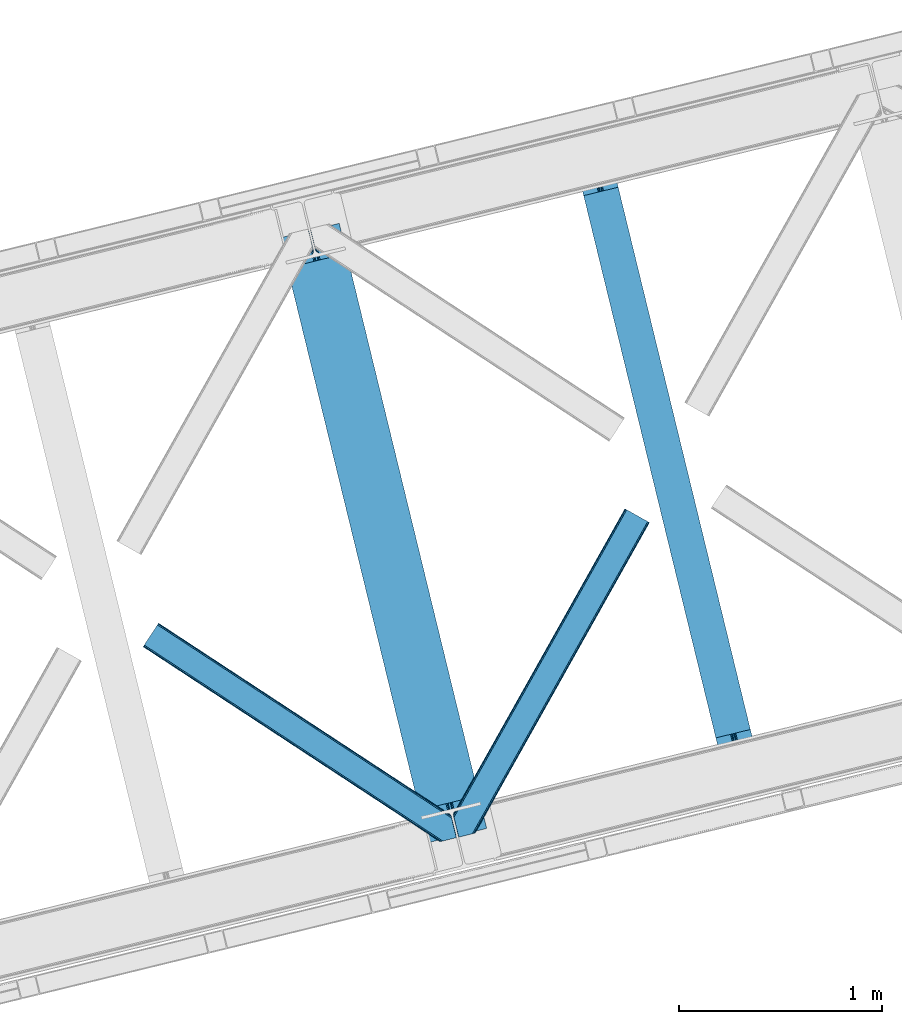
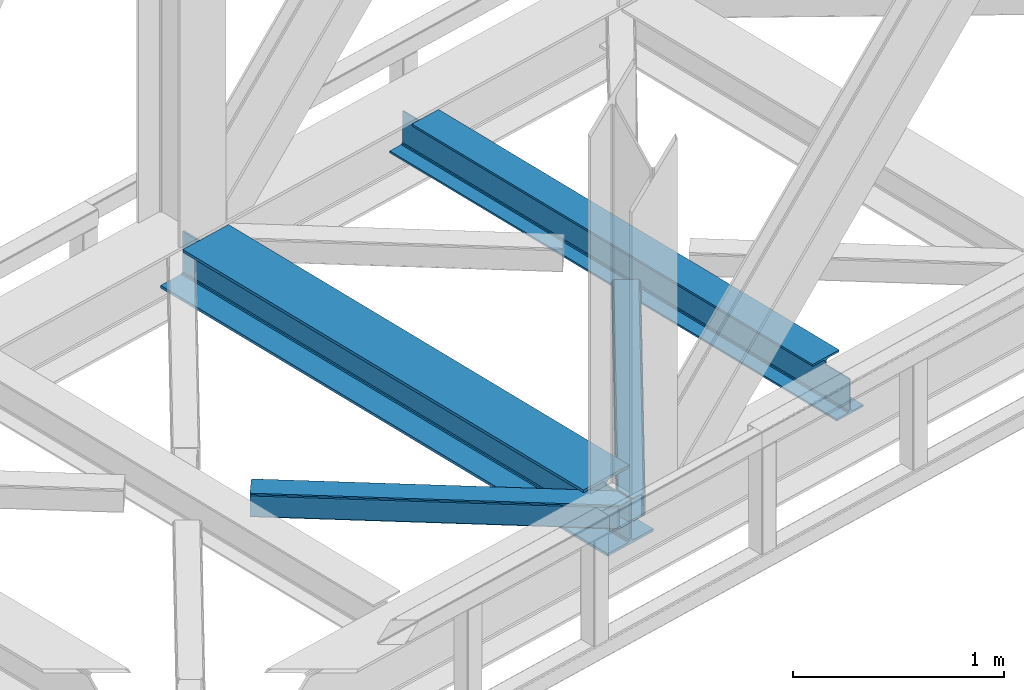
# One storey, part 78 of 93: 2 beams, 2 members.
"""IFC4 building model written with IfcOpenShell, lengths in millimetres."""

from ifc_helpers import new_model, entity, si_unit, converted_unit, derived_unit, direction, frame, origin, place, context, subcontext, project, spatial, triangles, polygons, material, type_object, element, save


model = new_model("IFC4")

# Units and contexts
model_context = context("Model", 3, precision=0.01, world=origin(), true_north=direction((6.12303176911189e-17, 1.0)))
plan_context = context("Plan", 3, precision=0.01, world=origin(), true_north=direction((6.12303176911189e-17, 1.0)))
body_context = subcontext(model_context, "Body", "Model", "MODEL_VIEW")
ifc_project = project(units=[si_unit("LENGTHUNIT", "METRE", prefix="MILLI"), si_unit("AREAUNIT", "SQUARE_METRE"), si_unit("VOLUMEUNIT", "CUBIC_METRE"), converted_unit("PLANEANGLEUNIT", "DEGREE", entity("IfcRatioMeasure", 0.0174532925199433), si_unit("PLANEANGLEUNIT", "RADIAN"), dimensions=[0, 0, 0, 0, 0, 0, 0]), si_unit("MASSUNIT", "GRAM", prefix="KILO"), derived_unit("MASSDENSITYUNIT", [(si_unit("MASSUNIT", "GRAM", prefix="KILO"), 1), (si_unit("LENGTHUNIT", "METRE"), -3)]), derived_unit("MOMENTOFINERTIAUNIT", [(si_unit("LENGTHUNIT", "METRE"), 4)]), si_unit("TIMEUNIT", "SECOND"), si_unit("FREQUENCYUNIT", "HERTZ"), si_unit("THERMODYNAMICTEMPERATUREUNIT", "DEGREE_CELSIUS"), derived_unit("THERMALTRANSMITTANCEUNIT", [(si_unit("MASSUNIT", "GRAM", prefix="KILO"), 1), (si_unit("THERMODYNAMICTEMPERATUREUNIT", "KELVIN"), -1), (si_unit("TIMEUNIT", "SECOND"), -3)]), derived_unit("VOLUMETRICFLOWRATEUNIT", [(si_unit("LENGTHUNIT", "METRE"), 3), (si_unit("TIMEUNIT", "SECOND"), -1)]), derived_unit("MASSFLOWRATEUNIT", [(si_unit("MASSUNIT", "GRAM", prefix="KILO"), 1), (si_unit("TIMEUNIT", "SECOND"), -1)]), derived_unit("ROTATIONALFREQUENCYUNIT", [(si_unit("TIMEUNIT", "SECOND"), -1)]), si_unit("ELECTRICCURRENTUNIT", "AMPERE"), si_unit("ELECTRICVOLTAGEUNIT", "VOLT"), si_unit("POWERUNIT", "WATT"), si_unit("FORCEUNIT", "NEWTON", prefix="KILO"), si_unit("ILLUMINANCEUNIT", "LUX"), si_unit("LUMINOUSFLUXUNIT", "LUMEN"), si_unit("LUMINOUSINTENSITYUNIT", "CANDELA"), derived_unit("USERDEFINED", [(si_unit("MASSUNIT", "GRAM", prefix="KILO"), -1), (si_unit("LENGTHUNIT", "METRE"), -2), (si_unit("TIMEUNIT", "SECOND"), 3), (si_unit("LUMINOUSFLUXUNIT", "LUMEN"), 1)]), derived_unit("LINEARVELOCITYUNIT", [(si_unit("LENGTHUNIT", "METRE"), 1), (si_unit("TIMEUNIT", "SECOND"), -1)]), si_unit("PRESSUREUNIT", "PASCAL"), derived_unit("USERDEFINED", [(si_unit("LENGTHUNIT", "METRE"), -2), (si_unit("MASSUNIT", "GRAM", prefix="KILO"), 1), (si_unit("TIMEUNIT", "SECOND"), -2)]), derived_unit("LINEARFORCEUNIT", [(si_unit("MASSUNIT", "GRAM", prefix="KILO"), 1), (si_unit("LENGTHUNIT", "METRE"), 1), (si_unit("TIMEUNIT", "SECOND"), -2), (si_unit("LENGTHUNIT", "METRE"), -1)]), derived_unit("PLANARFORCEUNIT", [(si_unit("MASSUNIT", "GRAM", prefix="KILO"), 1), (si_unit("LENGTHUNIT", "METRE"), 1), (si_unit("TIMEUNIT", "SECOND"), -2), (si_unit("LENGTHUNIT", "METRE"), -2)])], contexts=[model_context, plan_context])

# Site, building, storey
site_placement = place(None, origin())
site = spatial("IfcSite", under=ifc_project, at=site_placement, CompositionType="ELEMENT")
building_placement = place(site_placement, origin())
building = spatial("IfcBuilding", under=site, at=building_placement, CompositionType="ELEMENT")
storey_placement = place(building_placement, frame((0.0, 0.0, 15900.0)))
storey = spatial("IfcBuildingStorey", under=building, at=storey_placement, CompositionType="ELEMENT", Elevation=15900.0)

# Beams
ifc_material = material(Name="Metal painted (White)")
beam_type = type_object("IfcBeamType", PredefinedType="BEAM")
beam_1_placement = place(storey_placement, frame((-9086.33270000327, 15580.0394855194, 3385.0)))
element("IfcBeam", 1, at=beam_1_placement, inside=storey, type_object=beam_type, material=ifc_material, ObjectType="Steel Beam", PredefinedType="BEAM", context=body_context, shape_type="Tessellation", body=[
    polygons([(1018.1664837833, 71.0478278971021, 15.4999999999986), (1018.1664837833, 71.0478278971021, 0.0), (291.465617442452, 3052.25531830421, 0.0), (291.465617442452, 3052.25531830421, 15.4999999999986), (894.779372399334, 40.9709140873313, 15.4999999999986), (168.078506058486, 3022.17840449444, 15.4999999999986), (888.08702862538, 39.3395844888265, 16.8701684147963), (161.386162284532, 3020.54707489594, 16.8701684147963), (882.413533524765, 37.956610033654, 20.7720779386456), (155.712667183913, 3019.16410044077, 20.7720779386456), (878.622625296187, 37.0325360459184, 26.6116982174294), (151.921758955338, 3018.24002645303, 26.6116982174294), (877.291435352789, 36.7080444135029, 33.500000000001), (150.590569011938, 3017.91553482062, 33.500000000001), (140.875048430526, 3015.54727389071, 33.500000000001), (140.875048430525, 3015.54727389071, 259.000000000002), (150.590569011936, 3017.91553482062, 259.000000000002), (0.0, 2981.20749040711, 0.0), (3.24860138789518e-12, 2981.20749040711, 15.4999999999986), (123.387111383965, 3011.28440421689, 15.4999999999986), (130.079455157938, 3012.91573381539, 16.8701684147963), (135.752950258552, 3014.29870827056, 20.7720779386369), (139.543858487129, 3015.2227822583, 26.6116982174294), (877.291435352786, 36.7080444135029, 259.000000000002), (867.575914771374, 34.3397834836014, 259.000000000002), (867.575914771377, 34.3397834836014, 33.500000000001), (866.24472482798, 34.0152918511859, 26.6116982174294), (862.453816599403, 33.0912178634502, 20.7720779386369), (856.780321498787, 31.70824340828, 16.8701684147963), (850.087977724816, 30.0769138097708, 15.4999999999986), (726.700866340855, 0.0, 15.4999999999986), (726.700866340851, 0.0, 0.0), (838.124523615913, 197.385937999181, 259.069791973884), (186.469722099971, 2870.72539801219, 259.000000000002), (186.693115201823, 2869.80895360721, 259.61730333112), (186.70550404545, 2869.75812937344, 266.500003008253), (837.979344808147, 197.981416001704, 266.500002998871), (837.979694928899, 197.979979696973, 260.000004007589), (828.499586345882, 194.645865944434, 259.006343171919), (828.27621632612, 195.562317481914, 259.61730333112), (828.263827482491, 195.613141715687, 266.500003008253), (176.989986719794, 2867.38985508742, 266.500002998871), (176.989636599042, 2867.39129139215, 260.000004007589), (176.844830940702, 2867.98534020594, 259.07612046749), (176.75420151856, 2868.35713708228, 259.000000000002), (839.310832678078, 198.30468544639, 273.388305639783), (843.101109266769, 199.231350618303, 279.227924098777), (848.774180214308, 200.616065081981, 283.129832400619), (855.466371895439, 202.248018612794, 284.500000377228), (978.853400583268, 232.325271667905, 284.500000138971), (978.851730776625, 232.332121736637, 299.999995328161), (687.386308679347, 161.283492472596, 299.999995890962), (687.387978486002, 161.276642403863, 284.500000701776), (810.775007173842, 191.353895458974, 284.500000463519), (817.467494070002, 192.984637925557, 283.129832461069), (823.141405718754, 194.365903570079, 279.227924137322), (826.93294050575, 195.287407219375, 273.388305663684), (175.658498849867, 2867.06658564273, 273.388305639783), (171.868222261169, 2866.13992047082, 279.227924098781), (166.195151313643, 2864.75520600715, 283.129832400619), (159.502959632494, 2863.12325247633, 284.500000377228), (36.1159309446587, 2833.04599942122, 284.500000138971), (36.117600751305, 2833.03914935249, 299.999995328161), (327.583022848581, 2904.08777861653, 299.999995890962), (327.581353041927, 2904.09462868526, 284.500000701776), (204.194324354092, 2874.01737563015, 284.500000463519), (197.50183745795, 2872.38663316357, 283.129832461069), (191.827925809185, 2871.00536751905, 279.227924137318), (188.036391022194, 2870.08386386975, 273.388305663684)], [[[1, 2, 3, 4]], [[5, 1, 4, 6]], [[7, 5, 6, 8]], [[9, 7, 8, 10]], [[11, 9, 10, 12]], [[13, 11, 12, 14]], [[15, 16, 17, 14, 12, 10, 8, 6, 4, 3, 18, 19, 20, 21, 22, 23]], [[13, 24, 25, 26, 27, 28, 29, 30, 31, 32, 2, 1, 5, 7, 9, 11]], [[2, 32, 18, 3]], [[32, 31, 19, 18]], [[31, 30, 20, 19]], [[27, 26, 15, 23]], [[28, 27, 23, 22]], [[29, 28, 22, 21]], [[30, 29, 21, 20]], [[33, 24, 13, 14, 17, 34, 35, 36, 37, 38]], [[25, 39, 40, 41, 42, 43, 44, 16, 15, 26]], [[39, 25, 24, 33]], [[45, 34, 17, 16]], [[41, 40, 38, 37, 46, 47, 48, 49, 50, 51, 52, 53, 54, 55, 56, 57]], [[42, 58, 59, 60, 61, 62, 63, 64, 65, 66, 67, 68, 69, 36, 35, 43]], [[46, 37, 36, 69]], [[47, 46, 69, 68]], [[48, 47, 68, 67]], [[49, 48, 67, 66]], [[50, 49, 66, 65]], [[51, 50, 65, 64]], [[52, 51, 64, 63]], [[53, 52, 63, 62]], [[54, 53, 62, 61]], [[55, 54, 61, 60]], [[56, 55, 60, 59]], [[57, 56, 59, 58]], [[41, 57, 58, 42]]], closed=False),
])
beam_2_placement = place(storey_placement, frame((-7626.57573264569, 15935.8706902374, 3441.0)))
element("IfcBeam", 2, at=beam_2_placement, inside=storey, type_object=beam_type, material=ifc_material, ObjectType="Steel Beam", PredefinedType="BEAM", context=body_context, shape_type="Tessellation", body=[
    polygons([(896.722476515611, 41.4445662733103, 11.000000000004), (896.722476515614, 41.4445662733103, 2.16573425859679e-12), (170.021610174762, 3022.65205668042, 2.16573425859679e-12), (170.02161017476, 3022.65205668042, 11.000000000004), (830.656936561979, 25.3403919499634, 11.000000000004), (103.956070221129, 3006.54788235708, 11.000000000004), (824.708186540692, 23.8903211957374, 12.2179274798217), (98.0073201998416, 3005.09781160285, 12.2179274798217), (819.665079784588, 22.6610105689172, 15.686291501017), (92.9642134437373, 3003.86850097603, 15.686291501017), (816.295383581406, 21.8396114687097, 20.8770650821657), (89.594517240556, 3003.04710187582, 20.8770650821657), (815.112103631725, 21.5511744621184, 27.0000000000047), (88.4112372908755, 3002.75866486923, 27.0000000000047), (81.6103728838779, 3001.1008822183, 27.0000000000047), (81.6103728838768, 3001.1008822183, 203.000000000006), (88.411237290882, 3002.75866486923, 203.000000000006), (3.24860138789518e-12, 2981.20749040711, 2.16573425859679e-12), (3.24860138789518e-12, 2981.20749040711, 10.9999999999997), (66.0655399536161, 2997.31166473045, 11.000000000004), (72.0142899749205, 2998.76173548468, 12.2179274798217), (77.0573967310281, 2999.9910461115, 15.6862915010192), (80.427092934204, 3000.81244521171, 20.8770650821657), (815.112103631733, 21.5511744621227, 203.000000000006), (808.311239224728, 19.8933918111854, 203.000000000006), (808.311239224728, 19.8933918111854, 27.0000000000047), (807.127959275053, 19.6049548045984, 20.8770650821657), (803.758263071879, 18.7835557043887, 15.6862915010192), (798.715156315771, 17.5542450775707, 12.2179274798217), (792.766406294467, 16.1041743233403, 11.000000000004), (726.700866340853, 2.16573425859679e-12, 10.9999999999997), (726.700866340856, 2.16573425859679e-12, 2.16573425859679e-12), (775.945201911976, 182.229070489532, 203.069792164282), (124.290390378929, 2855.5685280608, 203.000000000006), (124.513271168076, 2854.65418562638, 203.617301946336), (124.526185412596, 2854.60120565348, 217.000003693143), (775.799998669246, 182.824605273256, 217.000003676718), (775.800869277144, 182.821033832377, 204.00000679514), (769.2349007589, 180.199471824625, 203.006342981088), (769.012053092174, 181.113823838952, 203.617301946336), (768.999138847647, 181.166803811845, 217.000003693143), (117.725325590999, 2852.94340419207, 217.000003676718), (117.724454983107, 2852.94697563295, 204.00000679514), (117.580155394048, 2853.53894853353, 203.076120467494), (117.489525971923, 2853.91074540987, 203.000000000006), (776.983483393265, 183.112202246694, 223.122939328039), (780.352479801945, 183.936472070573, 228.313710402595), (785.395115205969, 185.167716295879, 231.782072735464), (791.343694076666, 186.618489150559, 232.999999602236), (857.4091449422, 202.723028934495, 232.999999283132), (857.407671605763, 202.729072911368, 243.999994005812), (687.386290701845, 161.28356611448, 243.999994827032), (687.387764038282, 161.277522137607, 233.000000104353), (753.453214903794, 177.382061921539, 232.999999785253), (759.402120032139, 178.831496389766, 231.782072861012), (764.445684539266, 180.058929212901, 228.313710479427), (767.816071449004, 180.87749487033, 223.12293937232), (116.541840866978, 2852.65580721863, 223.122939328039), (113.172844458302, 2851.83153739476, 228.313710402595), (108.130209054283, 2850.60029316945, 231.782072735464), (102.181630183566, 2849.14952031477, 232.999999602236), (36.1161793180469, 2833.04498053083, 232.999999283128), (36.1176526544877, 2833.03893655396, 243.999994005812), (206.139033558404, 2874.48444335085, 243.999994827032), (206.137560221967, 2874.49048732772, 233.000000104357), (140.072109356437, 2858.38594754379, 232.999999785253), (134.123204228111, 2856.93651307557, 231.782072861012), (129.079639720983, 2855.70908025243, 228.313710479427), (125.709252811239, 2854.890514595, 223.12293937232)], [[[1, 2, 3, 4]], [[5, 1, 4, 6]], [[7, 5, 6, 8]], [[9, 7, 8, 10]], [[11, 9, 10, 12]], [[13, 11, 12, 14]], [[15, 16, 17, 14, 12, 10, 8, 6, 4, 3, 18, 19, 20, 21, 22, 23]], [[13, 24, 25, 26, 27, 28, 29, 30, 31, 32, 2, 1, 5, 7, 9, 11]], [[2, 32, 18, 3]], [[32, 31, 19, 18]], [[31, 30, 20, 19]], [[27, 26, 15, 23]], [[28, 27, 23, 22]], [[29, 28, 22, 21]], [[30, 29, 21, 20]], [[33, 24, 13, 14, 17, 34, 35, 36, 37, 38]], [[25, 39, 40, 41, 42, 43, 44, 16, 15, 26]], [[39, 25, 24, 33]], [[45, 34, 17, 16]], [[41, 40, 38, 37, 46, 47, 48, 49, 50, 51, 52, 53, 54, 55, 56, 57]], [[42, 58, 59, 60, 61, 62, 63, 64, 65, 66, 67, 68, 69, 36, 35, 43]], [[46, 37, 36, 69]], [[47, 46, 69, 68]], [[48, 47, 68, 67]], [[49, 48, 67, 66]], [[50, 49, 66, 65]], [[51, 50, 65, 64]], [[52, 51, 64, 63]], [[53, 52, 63, 62]], [[54, 53, 62, 61]], [[55, 54, 61, 60]], [[56, 55, 60, 59]], [[57, 56, 59, 58]], [[41, 57, 58, 42]]], closed=False),
])

# Members
member_type_1 = type_object("IfcMemberType", PredefinedType="BRACE")
member_1_placement = place(storey_placement, frame((-8233.36081695557, 15608.2403137207, 3510.00011901855)))
element("IfcMember", 3, at=member_1_placement, inside=storey, type_object=member_type_1, ObjectType="Steel Horizontal Brace", PredefinedType="BRACE", context=body_context, shape_type="Tessellation", body=[
    triangles([(967.681050109863, 1549.66471252441, 122.500662231447), (966.521237182617, 1550.31699829101, 129.197927856447), (108.493377685547, 19.761584472657, 122.500662231447), (106.721974182128, 19.3302154541016, 129.197927856447), (963.215043640136, 1552.17502441406, 134.874325561526), (101.679258728027, 18.1012207031254, 134.874325561526), (958.263020324707, 1554.95392456055, 138.667117309571), (94.1378585815428, 16.2629608154293, 138.667117309571), (952.422679138183, 1558.23395690918, 139.999594116212), (85.2360763549805, 14.0921630859375, 139.999594116212), (967.681050109863, 1549.66471252441, 17.5000946044929), (108.493377685547, 19.761584472657, 17.5000946044929), (6.07462921142542, 87.5702362060547, 139.999594116212), (27.4210006713856, 0.0, 139.999594116212), (860.874778747559, 1609.64826049805, 139.999594116212), (855.034437561035, 1612.92829284668, 138.667117309571), (3.74977111816406, 97.1068634033199, 138.667117309571), (850.082414245605, 1615.70719299316, 134.874325561526), (1.77896118164063, 105.192416381837, 134.874325561526), (846.776220703125, 1617.56521911621, 129.197927856447), (0.462181091308594, 110.594412231445, 129.197927856447), (845.616407775879, 1618.21750488281, 122.500662231447), (0.0, 112.491970825195, 122.500662231447), (845.616407775879, 1618.21750488281, 17.5000946044929), (0.0, 112.491970825195, 17.5000946044929), (966.521237182617, 1550.31699829101, 10.8028289794929), (106.721974182128, 19.3302154541016, 10.8028289794929), (156.767756652832, 115.413885498047, 5.52059326172093), (963.215043640136, 1552.17502441406, 5.12526855468968), (156.952047729492, 116.778918457032, 5.02062377929906), (102.189692687988, 18.2256317138672, 5.52059326172093), (958.263020324707, 1554.95392456055, 1.33247680664135), (157.131687927245, 118.142788696288, 4.52065429687718), (155.381794738769, 125.321420288086, 1.33247680664135), (952.422679138183, 1558.23395690918, 0.0), (153.056936645507, 134.858047485352, 0.0), (124.438916015624, 252.261346435547, 0.0), (94.4628387451166, 244.953652954102, 0.0), (860.874778747559, 1609.64826049805, 0.0), (77.5132919311518, 240.822509765625, 5.52059326172093), (85.5657073974608, 242.785180664063, 1.33247680664135), (123.842440795898, 252.116006469727, 5.44385375976708), (124.438916015624, 252.261346435547, 4.52065429687718), (846.776220703125, 1617.56521911621, 10.8028289794929), (1.68013000488281, 112.178036499023, 10.9621215820334), (0.251147460936409, 111.460638427734, 12.5201660156272), (850.082414245605, 1615.70719299316, 5.12526855468968), (855.034437561035, 1612.92829284668, 1.33247680664135), (6.66994171142505, 114.682534790039, 5.52059326172093), (34.2211669921871, 1.65687561035156, 5.52059326172093), (123.467463684082, 252.024151611327, 5.52059326172093), (32.7846267700188, 1.30689697265552, 6.99957275390625), (12.4672622680664, 84.6564605712883, 6.99957275390625), (9.18839263916016, 92.4908660888668, 8.3320495605476), (4.07649536132703, 95.7674102783203, 12.5201660156272), (75.9366439819332, 11.8260223388679, 6.99957275390625), (946.321307373047, 1561.66165466309, 6.99957275390625), (866.976150512695, 1606.22056274414, 6.99957275390625), (861.135809326172, 1609.49943237305, 8.3320495605476), (856.187855529784, 1612.28065795899, 12.1260040283232), (852.877592468261, 1614.1375213623, 17.8035644531265), (2.89226531982422, 100.625253295899, 17.8035644531265), (851.717779541015, 1614.78980712891, 24.4996673583992), (2.43008422851563, 102.522811889648, 24.4996673583992), (961.579678344727, 1553.09241027832, 24.4996673583992), (960.415214538574, 1553.7435333252, 17.8035644531265), (99.1892944335932, 17.4942810058601, 24.4996673583992), (97.4178909301754, 17.0617492675774, 17.8035644531265), (957.109602355957, 1555.60155944824, 12.1260040283232), (92.3798263549797, 15.8339172363285, 12.1260040283232), (952.16164855957, 1558.38278503418, 8.3320495605476), (84.8337753295891, 13.994494628907, 8.3320495605476), (961.579678344727, 1553.09241027832, 115.501089477541), (99.1892944335932, 17.4942810058601, 115.501089477541), (84.8337753295891, 13.994494628907, 131.667544555665), (75.9366439819332, 11.8260223388679, 133.000021362306), (27.4210006713856, 0.0, 133.000021362306), (92.3798263549797, 15.8339172363285, 127.87475280762), (97.4178909301754, 17.0617492675774, 122.196029663086), (946.321307373047, 1561.66165466309, 133.000021362306), (952.16164855957, 1558.38278503418, 131.667544555665), (957.109602355957, 1555.60155944824, 127.87475280762), (960.415214538574, 1553.7435333252, 122.196029663086), (856.187855529784, 1612.28065795899, 127.87475280762), (866.976150512695, 1606.22056274414, 133.000021362306), (861.135809326172, 1609.49943237305, 131.667544555665), (851.717779541015, 1614.78980712891, 115.501089477541), (852.877592468261, 1614.1375213623, 122.196029663086), (4.20904541015625, 95.2232574462887, 127.87475280762), (2.89226531982422, 100.625253295899, 122.196029663086), (6.17985534667969, 87.1377044677738, 131.667544555665), (8.50471343994104, 77.6010772705085, 133.000021362306), (2.43008422851563, 102.522811889648, 115.501089477541)], [[1, 2, 3], [4, 3, 2], [2, 5, 4], [6, 4, 5], [5, 7, 6], [8, 6, 7], [7, 9, 8], [10, 8, 9], [11, 1, 3], [3, 12, 11], [13, 10, 9], [10, 13, 14], [9, 15, 13], [15, 16, 17], [17, 13, 15], [16, 18, 19], [19, 17, 16], [18, 20, 21], [21, 19, 18], [20, 22, 23], [23, 21, 20], [22, 24, 25], [25, 23, 22], [26, 27, 28], [28, 29, 26], [28, 30, 29], [27, 31, 28], [30, 32, 29], [30, 33, 32], [33, 34, 32], [35, 32, 36], [34, 36, 32], [26, 11, 12], [12, 27, 26], [37, 38, 39], [36, 37, 35], [39, 35, 37], [38, 40, 41], [38, 37, 42], [38, 42, 40], [42, 37, 43], [43, 36, 33], [36, 43, 37], [34, 33, 36], [24, 44, 45], [45, 46, 24], [47, 48, 41], [45, 44, 40], [44, 47, 40], [40, 49, 45], [41, 40, 47], [48, 39, 38], [38, 41, 48], [46, 25, 24], [31, 49, 28], [31, 50, 49], [40, 28, 49], [51, 28, 40], [50, 52, 53], [49, 53, 54], [53, 49, 50], [55, 45, 49], [49, 54, 55], [46, 45, 55], [53, 56, 57], [56, 53, 52], [57, 58, 53], [59, 60, 55], [60, 61, 62], [62, 55, 60], [61, 63, 64], [64, 62, 61], [58, 59, 54], [54, 53, 58], [55, 54, 59], [65, 66, 67], [68, 67, 66], [66, 69, 68], [70, 68, 69], [69, 71, 70], [72, 70, 71], [71, 57, 72], [56, 72, 57], [73, 65, 67], [67, 74, 73], [8, 10, 75], [14, 76, 10], [76, 14, 77], [76, 75, 10], [78, 8, 75], [78, 6, 8], [6, 79, 4], [79, 6, 78], [3, 79, 74], [79, 3, 4], [56, 31, 72], [68, 70, 31], [70, 72, 31], [56, 50, 31], [50, 56, 52], [67, 68, 12], [27, 12, 68], [3, 67, 12], [67, 3, 74], [68, 31, 27], [80, 81, 75], [75, 76, 80], [81, 82, 78], [78, 75, 81], [82, 83, 79], [79, 78, 82], [83, 73, 74], [74, 79, 83], [26, 69, 66], [65, 1, 11], [26, 66, 11], [26, 29, 69], [66, 65, 11], [69, 29, 32], [57, 35, 39], [35, 71, 32], [71, 35, 57], [71, 69, 32], [2, 82, 5], [73, 1, 65], [1, 83, 2], [83, 1, 73], [2, 83, 82], [9, 80, 15], [7, 5, 82], [82, 81, 7], [81, 80, 9], [9, 7, 81], [60, 48, 47], [39, 58, 57], [39, 59, 58], [59, 39, 48], [60, 59, 48], [63, 24, 22], [44, 61, 60], [47, 44, 60], [61, 44, 24], [63, 61, 24], [16, 84, 18], [15, 80, 85], [85, 86, 15], [86, 84, 16], [16, 15, 86], [20, 18, 84], [22, 87, 63], [88, 22, 20], [22, 88, 87], [88, 20, 84], [89, 19, 90], [91, 92, 13], [92, 14, 13], [92, 77, 14], [17, 91, 13], [89, 17, 19], [89, 91, 17], [23, 64, 93], [21, 90, 19], [93, 90, 23], [90, 21, 23], [25, 64, 23], [46, 55, 62], [62, 64, 25], [25, 46, 62], [76, 92, 80], [76, 77, 92], [85, 80, 92], [63, 87, 93], [93, 64, 63], [87, 88, 93], [90, 93, 88], [88, 84, 90], [89, 90, 84], [84, 86, 89], [91, 89, 86], [86, 85, 91], [92, 91, 85]]),
])
member_type_2 = type_object("IfcMemberType", PredefinedType="BRACE")
member_2_placement = place(storey_placement, frame((-9761.38092041016, 15585.6370422363, 3510.00011901855)))
element("IfcMember", 4, at=member_2_placement, inside=storey, type_object=member_type_2, ObjectType="Steel Horizontal Brace", PredefinedType="BRACE", context=body_context, shape_type="Tessellation", body=[
    triangles([(1516.36209411621, 132.252392578124, 122.500662231447), (1516.36209411621, 132.252392578124, 17.5000946044929), (76.8296127319336, 1077.23657226563, 17.5000946044929), (76.8296127319336, 1077.23657226563, 122.500662231447), (1516.82427520752, 130.355996704102, 129.197927856447), (76.0959365844719, 1076.12152404785, 129.197927856447), (1518.14163665771, 124.954000854492, 134.874325561526), (74.0158309936523, 1072.95078735351, 134.874325561526), (1520.11244659424, 116.868447875977, 138.667117309571), (70.9026489257813, 1068.20572814941, 138.667117309571), (1522.43672332764, 107.331820678712, 139.999594116212), (67.226129150391, 1062.60723266601, 139.999594116212), (9.60290222167896, 974.828869628906, 139.999594116212), (1485.968019104, 5.66825866699219, 139.999594116212), (1543.7830947876, 19.761584472657, 139.999594116212), (1477.07088775635, 3.49978637695313, 138.667117309571), (5.92754516601599, 969.230374145507, 138.667117309571), (1469.52483673096, 1.66036376953161, 134.874325561526), (2.81378173828125, 964.485314941405, 134.874325561526), (1464.48677215576, 0.431369018555415, 129.197927856447), (0.733676147459846, 961.314578247071, 129.197927856447), (1462.71536865234, 0.0, 122.500662231447), (0.0, 960.199530029298, 122.500662231447), (1462.71536865234, 0.0, 17.5000946044929), (0.0, 960.199530029298, 17.5000946044929), (1516.61324157715, 131.222222900391, 12.5201660156272), (1515.01450195312, 131.20245666504, 10.9621215820334), (76.0959365844719, 1076.12152404785, 10.8028289794929), (1387.90133056641, 210.375531005859, 5.21247253418187), (74.0158309936523, 1072.95078735351, 5.12526855468968), (1509.43170318604, 131.129205322266, 5.52059326172093), (1380.44073944092, 208.557037353516, 1.33247680664135), (1371.53953857422, 206.387402343749, 0.0), (70.9026489257813, 1068.20572814941, 1.33247680664135), (67.226129150391, 1062.60723266601, 0.0), (1375.83462524414, 62.7066375732429, 5.51129150390625), (1387.90074920654, 210.375531005859, 5.38222961426072), (1509.43170318604, 131.129205322266, 5.43687744140698), (1342.53433227539, 199.316903686524, 5.39734497070458), (1469.0190536499, 1.53711547851526, 5.55431213379052), (1536.9829284668, 18.1035461425781, 5.53222045898656), (0.733676147459846, 961.314578247071, 10.8028289794929), (2.81378173828125, 964.485314941405, 5.12526855468968), (1375.04746398926, 63.8344757080085, 5.02062377929906), (5.92754516601599, 969.230374145507, 1.33247680664135), (1372.50575866699, 72.139782714843, 1.33247680664135), (1374.25565185547, 64.9611511230469, 4.52065429687718), (1370.18148193359, 81.6775726318356, 0.0), (9.60290222167896, 974.828869628906, 0.0), (1464.48677215576, 0.431369018555415, 10.8028289794929), (1469.0190536499, 1.53711547851526, 5.52059326172093), (1375.83462524414, 62.7066375732429, 5.52059326172093), (1341.56287994385, 199.079708862304, 0.0), (1342.53433227539, 199.316903686524, 5.52059326172093), (1341.56287994385, 199.079708862304, 4.52065429687718), (1520.43858947754, 115.528994750977, 12.5201660156272), (1517.41261138916, 110.268850708007, 8.3320495605476), (1538.41946868896, 18.4535247802742, 6.99957275390625), (1536.9829284668, 18.1035461425781, 5.52059326172093), (1518.10210418701, 101.803088378907, 6.99957275390625), (13.4468536376953, 980.68200073242, 6.99957275390625), (63.3821777343746, 1056.7541015625, 6.99957275390625), (1495.27152099609, 7.93556213378906, 6.99957275390625), (67.0586975097649, 1062.3525970459, 8.3320495605476), (70.1765304565433, 1067.09998168945, 12.1260040283232), (1519.25435943603, 120.386837768554, 17.8035644531265), (1518.79217834473, 122.284396362305, 24.4996673583992), (72.2566360473629, 1070.27071838379, 17.8035644531265), (72.9856613159172, 1071.38344116211, 24.4996673583992), (1518.79217834473, 122.284396362305, 115.501089477541), (72.9856613159172, 1071.38344116211, 115.501089477541), (1520.57113952637, 114.984841918946, 127.87475280762), (1519.25435943603, 120.386837768554, 122.196029663086), (1524.86680755615, 97.3626617431637, 133.000021362306), (1522.54194946289, 106.899288940429, 131.667544555665), (1543.7830947876, 19.761584472657, 133.000021362306), (63.3821777343746, 1056.7541015625, 133.000021362306), (67.0586975097649, 1062.3525970459, 131.667544555665), (70.1765304565433, 1067.09998168945, 127.87475280762), (72.2566360473629, 1070.27071838379, 122.196029663086), (13.4468536376953, 980.68200073242, 133.000021362306), (1495.27152099609, 7.93556213378906, 133.000021362306), (6.65308227539026, 970.336120605469, 12.1260040283232), (9.77091522216688, 975.083505249022, 8.3320495605476), (3.84395141601453, 966.052661132813, 24.4996673583992), (4.57297668457068, 967.165383911131, 17.8035644531265), (6.65308227539026, 970.336120605469, 127.87475280762), (9.77091522216688, 975.083505249022, 131.667544555665), (3.84395141601453, 966.052661132813, 115.501089477541), (4.57297668457068, 967.165383911131, 122.196029663086), (1478.82891998291, 3.92766723632849, 127.87475280762), (1486.37438964844, 5.76708984375, 131.667544555665), (1473.78620452881, 2.69867248535229, 122.196029663086), (1472.0194519043, 2.26846618652417, 115.501089477541), (1472.0194519043, 2.26846618652417, 24.4996673583992), (1478.82891998291, 3.92766723632849, 12.1260040283232), (1473.78620452881, 2.69867248535229, 17.8035644531265), (1486.37438964844, 5.76708984375, 8.3320495605476)], [[1, 2, 3], [3, 4, 1], [5, 1, 6], [4, 6, 1], [7, 5, 8], [6, 8, 5], [9, 7, 10], [8, 10, 7], [11, 9, 12], [10, 12, 9], [13, 11, 12], [11, 13, 14], [15, 11, 14], [16, 14, 13], [13, 17, 16], [18, 16, 17], [17, 19, 18], [20, 18, 19], [19, 21, 20], [22, 20, 21], [21, 23, 22], [24, 22, 25], [23, 25, 22], [3, 26, 27], [3, 2, 26], [28, 27, 29], [29, 30, 28], [27, 31, 29], [30, 29, 32], [32, 33, 34], [35, 34, 33], [32, 34, 30], [27, 28, 3], [36, 37, 38], [37, 36, 39], [38, 40, 36], [41, 40, 38], [42, 43, 44], [43, 45, 46], [46, 47, 43], [47, 44, 43], [48, 46, 45], [45, 49, 48], [50, 24, 42], [25, 42, 24], [51, 50, 52], [42, 52, 50], [53, 35, 33], [49, 53, 48], [53, 49, 35], [33, 54, 53], [29, 33, 32], [53, 54, 55], [29, 54, 33], [48, 55, 47], [48, 53, 55], [47, 46, 48], [56, 31, 27], [57, 31, 56], [27, 26, 56], [58, 59, 60], [60, 31, 57], [31, 60, 59], [61, 60, 62], [60, 61, 63], [58, 60, 63], [64, 57, 56], [65, 56, 66], [66, 67, 68], [69, 68, 67], [66, 68, 65], [56, 65, 64], [60, 57, 62], [64, 62, 57], [67, 70, 71], [71, 69, 67], [72, 7, 9], [7, 72, 73], [74, 75, 11], [75, 72, 9], [76, 74, 15], [11, 15, 74], [75, 9, 11], [26, 66, 56], [2, 1, 67], [67, 66, 2], [26, 2, 66], [1, 70, 67], [73, 5, 7], [1, 5, 73], [70, 1, 73], [75, 74, 77], [77, 78, 75], [72, 75, 78], [78, 79, 72], [73, 72, 79], [79, 80, 73], [70, 73, 80], [80, 71, 70], [81, 74, 82], [81, 77, 74], [74, 76, 82], [28, 65, 68], [69, 4, 3], [28, 68, 3], [28, 30, 65], [68, 69, 3], [65, 30, 34], [62, 35, 49], [35, 64, 34], [64, 35, 62], [64, 65, 34], [6, 79, 8], [71, 4, 69], [4, 80, 6], [80, 4, 71], [6, 80, 79], [12, 77, 13], [10, 8, 79], [79, 78, 10], [78, 77, 12], [12, 10, 78], [83, 45, 43], [49, 61, 62], [49, 84, 61], [84, 49, 45], [83, 84, 45], [85, 25, 23], [42, 86, 83], [43, 42, 83], [86, 42, 25], [85, 86, 25], [17, 87, 19], [13, 77, 81], [81, 88, 13], [88, 87, 17], [17, 13, 88], [21, 19, 87], [23, 89, 85], [90, 23, 21], [23, 90, 89], [90, 21, 87], [91, 92, 16], [18, 91, 16], [93, 18, 20], [93, 22, 94], [18, 93, 91], [22, 93, 20], [92, 14, 16], [15, 82, 76], [15, 14, 82], [92, 82, 14], [22, 95, 94], [51, 96, 97], [97, 95, 24], [24, 95, 22], [97, 50, 51], [50, 97, 24], [59, 63, 51], [63, 98, 51], [98, 96, 51], [59, 58, 63], [93, 94, 90], [89, 90, 94], [91, 93, 87], [90, 87, 93], [92, 91, 88], [87, 88, 91], [82, 92, 81], [88, 81, 92], [94, 95, 85], [85, 89, 94], [98, 63, 61], [61, 84, 98], [96, 98, 84], [84, 83, 96], [97, 96, 83], [83, 86, 97], [95, 97, 86], [86, 85, 95]]),
])

save(model, "model.ifc")
